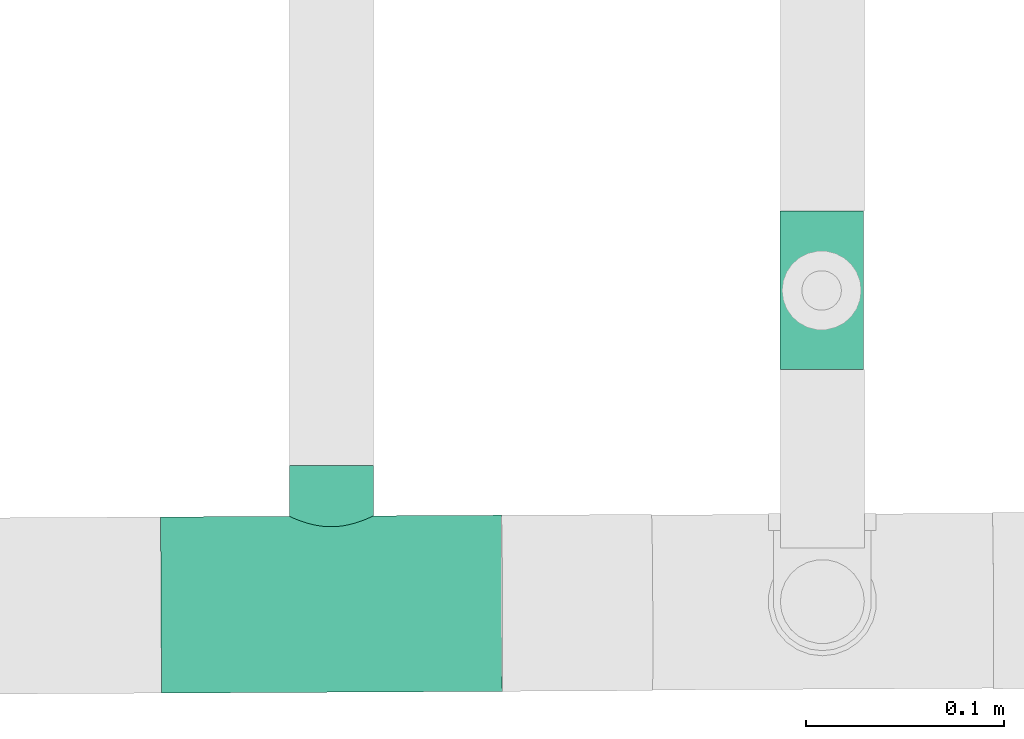
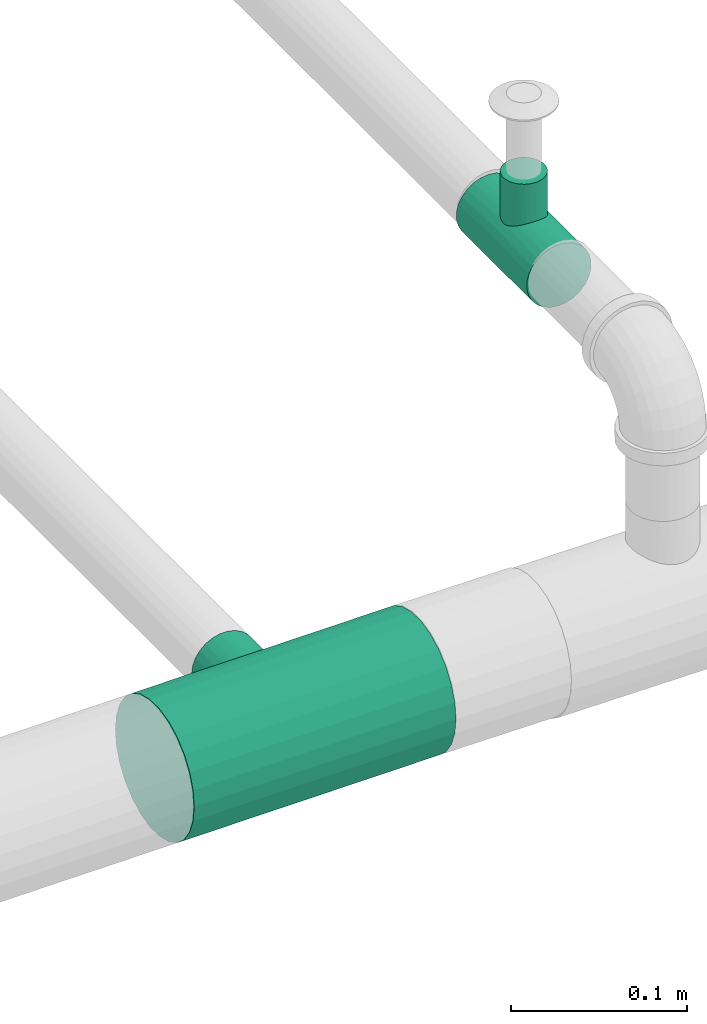
# One storey, part 4 of 7: 2 pipe fittings.
"""IFC4 building model written with IfcOpenShell, lengths in millimetres."""

from ifc_helpers import new_model, entity, si_unit, converted_unit, derived_unit, direction, frame, origin, place, context, subcontext, project, spatial, source, transform, mapped, type_object, type_shapes, element, save


model = new_model("IFC4")

# Units and contexts
model_context = context("Model", 3, precision=0.01, world=origin(), true_north=direction((6.12303176911189e-17, 1.0)))
body_context = subcontext(model_context, "Body", "Model", "MODEL_VIEW")
ifc_project = project(units=[si_unit("LENGTHUNIT", "METRE", prefix="MILLI"), si_unit("AREAUNIT", "SQUARE_METRE"), si_unit("VOLUMEUNIT", "CUBIC_METRE"), converted_unit("PLANEANGLEUNIT", "DEGREE", entity("IfcRatioMeasure", 0.0174532925199433), si_unit("PLANEANGLEUNIT", "RADIAN"), dimensions=[0, 0, 0, 0, 0, 0, 0]), si_unit("MASSUNIT", "GRAM", prefix="KILO"), derived_unit("MASSDENSITYUNIT", [(si_unit("MASSUNIT", "GRAM", prefix="KILO"), 1), (si_unit("LENGTHUNIT", "METRE"), -3)]), derived_unit("MOMENTOFINERTIAUNIT", [(si_unit("LENGTHUNIT", "METRE"), 4)]), si_unit("TIMEUNIT", "SECOND"), si_unit("FREQUENCYUNIT", "HERTZ"), si_unit("THERMODYNAMICTEMPERATUREUNIT", "DEGREE_CELSIUS"), derived_unit("THERMALTRANSMITTANCEUNIT", [(si_unit("MASSUNIT", "GRAM", prefix="KILO"), 1), (si_unit("THERMODYNAMICTEMPERATUREUNIT", "KELVIN"), -1), (si_unit("TIMEUNIT", "SECOND"), -3)]), derived_unit("VOLUMETRICFLOWRATEUNIT", [(si_unit("LENGTHUNIT", "METRE"), 3), (si_unit("TIMEUNIT", "SECOND"), -1)]), si_unit("ELECTRICCURRENTUNIT", "AMPERE"), si_unit("ELECTRICVOLTAGEUNIT", "VOLT"), si_unit("POWERUNIT", "WATT"), si_unit("FORCEUNIT", "NEWTON", prefix="KILO"), si_unit("ILLUMINANCEUNIT", "LUX"), si_unit("LUMINOUSFLUXUNIT", "LUMEN"), si_unit("LUMINOUSINTENSITYUNIT", "CANDELA"), derived_unit("USERDEFINED", [(si_unit("MASSUNIT", "GRAM", prefix="KILO"), -1), (si_unit("LENGTHUNIT", "METRE"), -2), (si_unit("TIMEUNIT", "SECOND"), 3), (si_unit("LUMINOUSFLUXUNIT", "LUMEN"), 1)]), derived_unit("LINEARVELOCITYUNIT", [(si_unit("LENGTHUNIT", "METRE"), 1), (si_unit("TIMEUNIT", "SECOND"), -1)]), si_unit("PRESSUREUNIT", "PASCAL"), derived_unit("USERDEFINED", [(si_unit("LENGTHUNIT", "METRE"), -2), (si_unit("MASSUNIT", "GRAM", prefix="KILO"), 1), (si_unit("TIMEUNIT", "SECOND"), -2)]), derived_unit("LINEARFORCEUNIT", [(si_unit("MASSUNIT", "GRAM", prefix="KILO"), 1), (si_unit("LENGTHUNIT", "METRE"), 1), (si_unit("TIMEUNIT", "SECOND"), -2), (si_unit("LENGTHUNIT", "METRE"), -1)]), derived_unit("PLANARFORCEUNIT", [(si_unit("MASSUNIT", "GRAM", prefix="KILO"), 1), (si_unit("LENGTHUNIT", "METRE"), 1), (si_unit("TIMEUNIT", "SECOND"), -2), (si_unit("LENGTHUNIT", "METRE"), -2)])], contexts=[model_context])

# Site, building, storey
site_placement = place(None, origin())
site = spatial("IfcSite", under=ifc_project, at=site_placement, CompositionType="ELEMENT")
building_placement = place(site_placement, origin())
building = spatial("IfcBuilding", under=site, at=building_placement, CompositionType="ELEMENT")
storey_placement = place(building_placement, origin())
storey = spatial("IfcBuildingStorey", under=building, at=storey_placement, Name="Ebene 1", CompositionType="ELEMENT", Elevation=0.0)

# Pipe fittings
pipe_fitting_type_1 = type_object("IfcPipeFittingType", PredefinedType="NOTDEFINED")
cartesian_point_1 = entity("IfcCartesianPoint", [-40.0, -21.2, 0.0])
vertex_point_1 = entity("IfcVertexPoint", cartesian_point_1)
cartesian_point_2 = entity("IfcCartesianPoint", [-40.0, 21.2, 0.0])
vertex_point_2 = entity("IfcVertexPoint", cartesian_point_2)
cartesian_point_3 = entity("IfcCartesianPoint", [-40.0, 0.0, 0.0])
ifc_direction_1 = entity("IfcDirection", [-1.0, 0.0, 0.0])
ifc_direction_2 = entity("IfcDirection", [0.0, 1.0, 0.0])
edge_curve_1 = entity("IfcEdgeCurve", vertex_point_1, vertex_point_2, entity("IfcTrimmedCurve", entity("IfcCircle", entity("IfcAxis2Placement3D", cartesian_point_3, ifc_direction_1, ifc_direction_2), 21.2), [cartesian_point_1], [cartesian_point_2], True, "CARTESIAN"), True)
edge_curve_2 = entity("IfcEdgeCurve", vertex_point_2, vertex_point_1, entity("IfcTrimmedCurve", entity("IfcCircle", entity("IfcAxis2Placement3D", cartesian_point_3, ifc_direction_1, ifc_direction_2), 21.2), [cartesian_point_2], [cartesian_point_1], True, "CARTESIAN"), True)
ifc_direction_3 = entity("IfcDirection", [0.0, 0.0, 1.0])
cartesian_point_4 = entity("IfcCartesianPoint", [-13.4499999999997, -21.2, 0.0])
vertex_point_3 = entity("IfcVertexPoint", cartesian_point_4)
ifc_direction_4 = entity("IfcDirection", [1.0, 0.0, 0.0])
edge_curve_3 = entity("IfcEdgeCurve", vertex_point_1, vertex_point_3, entity("IfcTrimmedCurve", entity("IfcLine", cartesian_point_1, entity("IfcVector", ifc_direction_4, 304.8)), [cartesian_point_1], [cartesian_point_4], True, "CARTESIAN"), True)
cartesian_point_5 = entity("IfcCartesianPoint", [0.0, -16.3871138398439, 13.4499999999999])
vertex_point_4 = entity("IfcVertexPoint", cartesian_point_5)
edge_curve_4 = entity("IfcEdgeCurve", vertex_point_3, vertex_point_4, entity("IfcBSplineCurveWithKnots", 3, [cartesian_point_4, entity("IfcCartesianPoint", [-13.4426718173683, -21.2, 1.05530479408136]), entity("IfcCartesianPoint", [-13.2097756163524, -21.0441868349683, 3.10767628539556]), entity("IfcCartesianPoint", [-12.1609162088206, -20.397991088886, 6.00505446288426]), entity("IfcCartesianPoint", [-10.5469284915267, -19.4669340412135, 8.51865656427646]), entity("IfcCartesianPoint", [-8.63574644559518, -18.49532904545, 10.4164641581798]), entity("IfcCartesianPoint", [-7.05510952350422, -17.825657912175, 11.4858433011898]), entity("IfcCartesianPoint", [-6.07427551785178, -17.4735158488194, 12.0060897801005]), entity("IfcCartesianPoint", [-5.40578101167897, -17.2531617437123, 12.3219689547776]), entity("IfcCartesianPoint", [-4.53058927081207, -16.9921793940957, 12.6801028111429]), entity("IfcCartesianPoint", [-3.44008605195583, -16.729896481067, 13.0228623624602]), entity("IfcCartesianPoint", [-1.95789476503921, -16.4810375094563, 13.336536578552]), entity("IfcCartesianPoint", [-0.795851700402365, -16.3955749834363, 13.4396911729914]), cartesian_point_5], "UNSPECIFIED", False, "UNKNOWN", [4, 1, 1, 1, 1, 1, 1, 1, 1, 1, 1, 4], [0.0, 0.142857142857143, 0.285714285714286, 0.428571428571429, 0.571428571428571, 0.678571428571429, 0.705357142857143, 0.732142857142857, 0.785714285714286, 0.839285714285714, 0.892857142857143, 1.0], "UNSPECIFIED"), True)
cartesian_point_6 = entity("IfcCartesianPoint", [0.0, 21.2, 0.0])
vertex_point_5 = entity("IfcVertexPoint", cartesian_point_6)
cartesian_point_7 = entity("IfcCartesianPoint", [0.0, 0.0, 0.0])
edge_curve_5 = entity("IfcEdgeCurve", vertex_point_4, vertex_point_5, entity("IfcTrimmedCurve", entity("IfcCircle", entity("IfcAxis2Placement3D", cartesian_point_7, ifc_direction_1, ifc_direction_2), 21.2), [cartesian_point_5], [cartesian_point_6], True, "CARTESIAN"), True)
edge_curve_6 = entity("IfcEdgeCurve", vertex_point_5, vertex_point_2, entity("IfcTrimmedCurve", entity("IfcLine", cartesian_point_2, entity("IfcVector", ifc_direction_1, 304.8)), [cartesian_point_6], [cartesian_point_2], True, "CARTESIAN"), True)
cartesian_point_8 = entity("IfcCartesianPoint", [0.0, -16.3871138398438, -13.45])
vertex_point_6 = entity("IfcVertexPoint", cartesian_point_8)
edge_curve_7 = entity("IfcEdgeCurve", vertex_point_5, vertex_point_6, entity("IfcTrimmedCurve", entity("IfcCircle", entity("IfcAxis2Placement3D", cartesian_point_7, ifc_direction_1, ifc_direction_2), 21.2), [cartesian_point_6], [cartesian_point_8], True, "CARTESIAN"), True)
edge_curve_8 = entity("IfcEdgeCurve", vertex_point_6, vertex_point_3, entity("IfcBSplineCurveWithKnots", 3, [cartesian_point_8, entity("IfcCartesianPoint", [-0.530567800268229, -16.3927546022388, -13.443127448661]), entity("IfcCartesianPoint", [-1.57322183506307, -16.4472972724825, -13.3768527398099]), entity("IfcCartesianPoint", [-3.07552569521692, -16.6498835557472, -13.1256228919224]), entity("IfcCartesianPoint", [-4.29162915568002, -16.9288024160368, -12.7647972300529]), entity("IfcCartesianPoint", [-5.23159362826072, -17.200165075527, -12.3950483027885]), entity("IfcCartesianPoint", [-6.13646755642774, -17.4882712267364, -11.9882121037541]), entity("IfcCartesianPoint", [-7.21336443959599, -17.8915799642873, -11.3853223452529]), entity("IfcCartesianPoint", [-8.8092327863119, -18.5829320362105, -10.244778111581]), entity("IfcCartesianPoint", [-10.3708595681595, -19.3781525936877, -8.69330270117763]), entity("IfcCartesianPoint", [-11.5633465632856, -20.0508934534462, -6.94488315746441]), entity("IfcCartesianPoint", [-12.2393860181753, -20.4531409633993, -5.6114001730771]), entity("IfcCartesianPoint", [-12.6719579269079, -20.7152170553906, -4.55307873733241]), entity("IfcCartesianPoint", [-13.0180907128958, -20.927114158807, -3.45234159916712]), entity("IfcCartesianPoint", [-13.3415546521607, -21.1333274469641, -1.95734501707586]), entity("IfcCartesianPoint", [-13.4445038630262, -21.2, -0.791478595561123]), cartesian_point_4], "UNSPECIFIED", False, "UNKNOWN", [4, 1, 1, 1, 1, 1, 1, 1, 1, 1, 1, 1, 1, 1, 4], [0.0, 0.0714285714285714, 0.142857142857143, 0.214285714285714, 0.25, 0.285714285714286, 0.357142857142857, 0.428571428571429, 0.571428571428571, 0.678571428571429, 0.732142857142857, 0.785714285714286, 0.839285714285714, 0.892857142857143, 1.0], "UNSPECIFIED"), True)
cartesian_point_9 = entity("IfcCartesianPoint", [40.0, -21.2, 0.0])
vertex_point_7 = entity("IfcVertexPoint", cartesian_point_9)
cartesian_point_10 = entity("IfcCartesianPoint", [40.0, 21.2, 0.0])
vertex_point_8 = entity("IfcVertexPoint", cartesian_point_10)
cartesian_point_11 = entity("IfcCartesianPoint", [40.0, 0.0, 0.0])
edge_curve_9 = entity("IfcEdgeCurve", vertex_point_7, vertex_point_8, entity("IfcTrimmedCurve", entity("IfcCircle", entity("IfcAxis2Placement3D", cartesian_point_11, ifc_direction_4, ifc_direction_2), 21.2), [cartesian_point_9], [cartesian_point_10], True, "CARTESIAN"), True)
edge_curve_10 = entity("IfcEdgeCurve", vertex_point_8, vertex_point_7, entity("IfcTrimmedCurve", entity("IfcCircle", entity("IfcAxis2Placement3D", cartesian_point_11, ifc_direction_4, ifc_direction_2), 21.2), [cartesian_point_10], [cartesian_point_9], True, "CARTESIAN"), True)
edge_curve_11 = entity("IfcEdgeCurve", vertex_point_8, vertex_point_5, entity("IfcTrimmedCurve", entity("IfcLine", cartesian_point_6, entity("IfcVector", ifc_direction_1, 304.8)), [cartesian_point_10], [cartesian_point_6], True, "CARTESIAN"), True)
cartesian_point_12 = entity("IfcCartesianPoint", [13.4500000000003, -21.2, 0.0])
vertex_point_9 = entity("IfcVertexPoint", cartesian_point_12)
edge_curve_12 = entity("IfcEdgeCurve", vertex_point_4, vertex_point_9, entity("IfcBSplineCurveWithKnots", 3, [cartesian_point_5, entity("IfcCartesianPoint", [0.531634819858689, -16.3928819135239, 13.442972336057]), entity("IfcCartesianPoint", [1.57607123818477, -16.4476933205109, 13.3763690869294]), entity("IfcCartesianPoint", [3.08013692881612, -16.6506796779383, 13.1246211485699]), entity("IfcCartesianPoint", [4.29659073867082, -16.9299917267641, 12.7632282221071]), entity("IfcCartesianPoint", [5.23642769214472, -17.2016325394637, 12.393015409334]), entity("IfcCartesianPoint", [6.14120270583486, -17.4899444504475, 11.9857781136098]), entity("IfcCartesianPoint", [7.21777415311232, -17.8933341358018, 11.3825736824291]), entity("IfcCartesianPoint", [8.81288762772699, -18.5847111247634, 10.2415736340777]), entity("IfcCartesianPoint", [10.3740935708438, -19.3798792732465, 8.68951359025296]), entity("IfcCartesianPoint", [11.5659357420418, -20.0524195056715, 6.94048257577652]), entity("IfcCartesianPoint", [12.2414593668596, -20.4543687508565, 5.60692331292446]), entity("IfcCartesianPoint", [12.673530290567, -20.7162241328193, 4.54849434738574]), entity("IfcCartesianPoint", [13.0191628472021, -20.9278248733526, 3.44796327191625]), entity("IfcCartesianPoint", [13.3420958063374, -21.1335673799666, 1.95422154961542]), entity("IfcCartesianPoint", [13.4447017410778, -21.2, 0.790026683599578]), cartesian_point_12], "UNSPECIFIED", False, "UNKNOWN", [4, 1, 1, 1, 1, 1, 1, 1, 1, 1, 1, 1, 1, 1, 4], [0.0, 0.0714285714285714, 0.142857142857143, 0.214285714285714, 0.25, 0.285714285714286, 0.357142857142857, 0.428571428571429, 0.571428571428571, 0.678571428571429, 0.732142857142857, 0.785714285714286, 0.839285714285714, 0.892857142857143, 1.0], "UNSPECIFIED"), True)
edge_curve_13 = entity("IfcEdgeCurve", vertex_point_9, vertex_point_7, entity("IfcTrimmedCurve", entity("IfcLine", cartesian_point_12, entity("IfcVector", ifc_direction_4, 304.8)), [cartesian_point_12], [cartesian_point_9], True, "CARTESIAN"), True)
edge_curve_14 = entity("IfcEdgeCurve", vertex_point_9, vertex_point_6, entity("IfcBSplineCurveWithKnots", 3, [cartesian_point_12, entity("IfcCartesianPoint", [13.4429356547703, -21.2, -1.05336891146624]), entity("IfcCartesianPoint", [13.2106284272924, -21.0448079646393, -3.10290146454885]), entity("IfcCartesianPoint", [12.1632059848055, -20.3993567445884, -6.00052882100487]), entity("IfcCartesianPoint", [10.5500999116973, -19.4686677379271, -8.51474527268791]), entity("IfcCartesianPoint", [8.63944721325947, -18.497105971094, -10.4133430093872]), entity("IfcCartesianPoint", [7.05961182247531, -17.8274179790001, -11.4831210854999]), entity("IfcCartesianPoint", [6.07901331931581, -17.4751595806235, -12.0036988371641]), entity("IfcCartesianPoint", [5.41057777067569, -17.2546782201018, -12.3198496975246]), entity("IfcCartesianPoint", [4.53554903963236, -16.9934445856902, -12.6784155954797]), entity("IfcCartesianPoint", [3.44485713961686, -16.7308038767085, -13.021701977829]), entity("IfcCartesianPoint", [1.96131523211392, -16.4815361622911, -13.3359276598797]), entity("IfcCartesianPoint", [0.797452229788015, -16.3957659503639, -13.4394585040857]), cartesian_point_8], "UNSPECIFIED", False, "UNKNOWN", [4, 1, 1, 1, 1, 1, 1, 1, 1, 1, 1, 4], [0.0, 0.142857142857143, 0.285714285714286, 0.428571428571429, 0.571428571428571, 0.678571428571429, 0.705357142857143, 0.732142857142857, 0.785714285714286, 0.839285714285714, 0.892857142857143, 1.0], "UNSPECIFIED"), True)
cartesian_point_13 = entity("IfcCartesianPoint", [-13.4499999999997, -48.0, 0.0])
vertex_point_10 = entity("IfcVertexPoint", cartesian_point_13)
cartesian_point_14 = entity("IfcCartesianPoint", [13.4500000000003, -48.0, 0.0])
vertex_point_11 = entity("IfcVertexPoint", cartesian_point_14)
cartesian_point_15 = entity("IfcCartesianPoint", [0.0, -48.0, 0.0])
ifc_direction_5 = entity("IfcDirection", [0.0, -1.0, 0.0])
edge_curve_15 = entity("IfcEdgeCurve", vertex_point_10, vertex_point_11, entity("IfcTrimmedCurve", entity("IfcCircle", entity("IfcAxis2Placement3D", cartesian_point_15, ifc_direction_5, ifc_direction_4), 13.45), [cartesian_point_13], [cartesian_point_14], True, "CARTESIAN"), True)
edge_curve_16 = entity("IfcEdgeCurve", vertex_point_11, vertex_point_10, entity("IfcTrimmedCurve", entity("IfcCircle", entity("IfcAxis2Placement3D", cartesian_point_15, ifc_direction_5, ifc_direction_4), 13.45), [cartesian_point_14], [cartesian_point_13], True, "CARTESIAN"), True)
edge_curve_17 = entity("IfcEdgeCurve", vertex_point_11, vertex_point_9, entity("IfcTrimmedCurve", entity("IfcLine", cartesian_point_12, entity("IfcVector", ifc_direction_2, 304.8)), [cartesian_point_14], [cartesian_point_12], True, "CARTESIAN"), True)
edge_curve_18 = entity("IfcEdgeCurve", vertex_point_3, vertex_point_10, entity("IfcTrimmedCurve", entity("IfcLine", cartesian_point_4, entity("IfcVector", ifc_direction_5, 304.8)), [cartesian_point_4], [cartesian_point_13], True, "CARTESIAN"), True)
shared_shape_1 = source(origin(), body_context, "Body", "AdvancedBrep", [
    entity("IfcAdvancedBrep", entity("IfcClosedShell", [entity("IfcAdvancedFace", [entity("IfcFaceOuterBound", entity("IfcEdgeLoop", [entity("IfcOrientedEdge", None, None, edge_curve_1, True), entity("IfcOrientedEdge", None, None, edge_curve_2, True)]), True)], entity("IfcPlane", entity("IfcAxis2Placement3D", cartesian_point_3, ifc_direction_1, ifc_direction_3)), True), entity("IfcAdvancedFace", [entity("IfcFaceOuterBound", entity("IfcEdgeLoop", [entity("IfcOrientedEdge", None, None, edge_curve_1, False), entity("IfcOrientedEdge", None, None, edge_curve_3, True), entity("IfcOrientedEdge", None, None, edge_curve_4, True), entity("IfcOrientedEdge", None, None, edge_curve_5, True), entity("IfcOrientedEdge", None, None, edge_curve_6, True)]), True)], entity("IfcCylindricalSurface", entity("IfcAxis2Placement3D", cartesian_point_3, ifc_direction_1, ifc_direction_2), 21.2), True), entity("IfcAdvancedFace", [entity("IfcFaceOuterBound", entity("IfcEdgeLoop", [entity("IfcOrientedEdge", None, None, edge_curve_2, False), entity("IfcOrientedEdge", None, None, edge_curve_6, False), entity("IfcOrientedEdge", None, None, edge_curve_7, True), entity("IfcOrientedEdge", None, None, edge_curve_8, True), entity("IfcOrientedEdge", None, None, edge_curve_3, False)]), True)], entity("IfcCylindricalSurface", entity("IfcAxis2Placement3D", cartesian_point_3, ifc_direction_1, ifc_direction_2), 21.2), True), entity("IfcAdvancedFace", [entity("IfcFaceOuterBound", entity("IfcEdgeLoop", [entity("IfcOrientedEdge", None, None, edge_curve_9, True), entity("IfcOrientedEdge", None, None, edge_curve_10, True)]), True)], entity("IfcPlane", entity("IfcAxis2Placement3D", cartesian_point_11, ifc_direction_4, ifc_direction_3)), True), entity("IfcAdvancedFace", [entity("IfcFaceOuterBound", entity("IfcEdgeLoop", [entity("IfcOrientedEdge", None, None, edge_curve_10, False), entity("IfcOrientedEdge", None, None, edge_curve_11, True), entity("IfcOrientedEdge", None, None, edge_curve_5, False), entity("IfcOrientedEdge", None, None, edge_curve_12, True), entity("IfcOrientedEdge", None, None, edge_curve_13, True)]), True)], entity("IfcCylindricalSurface", entity("IfcAxis2Placement3D", cartesian_point_7, ifc_direction_1, ifc_direction_2), 21.2), True), entity("IfcAdvancedFace", [entity("IfcFaceOuterBound", entity("IfcEdgeLoop", [entity("IfcOrientedEdge", None, None, edge_curve_9, False), entity("IfcOrientedEdge", None, None, edge_curve_13, False), entity("IfcOrientedEdge", None, None, edge_curve_14, True), entity("IfcOrientedEdge", None, None, edge_curve_7, False), entity("IfcOrientedEdge", None, None, edge_curve_11, False)]), True)], entity("IfcCylindricalSurface", entity("IfcAxis2Placement3D", cartesian_point_7, ifc_direction_1, ifc_direction_2), 21.2), True), entity("IfcAdvancedFace", [entity("IfcFaceOuterBound", entity("IfcEdgeLoop", [entity("IfcOrientedEdge", None, None, edge_curve_15, True), entity("IfcOrientedEdge", None, None, edge_curve_16, True)]), True)], entity("IfcPlane", entity("IfcAxis2Placement3D", cartesian_point_15, ifc_direction_5, ifc_direction_3)), True), entity("IfcAdvancedFace", [entity("IfcFaceOuterBound", entity("IfcEdgeLoop", [entity("IfcOrientedEdge", None, None, edge_curve_16, False), entity("IfcOrientedEdge", None, None, edge_curve_17, True), entity("IfcOrientedEdge", None, None, edge_curve_12, False), entity("IfcOrientedEdge", None, None, edge_curve_4, False), entity("IfcOrientedEdge", None, None, edge_curve_18, True)]), True)], entity("IfcCylindricalSurface", entity("IfcAxis2Placement3D", cartesian_point_7, ifc_direction_2, ifc_direction_4), 13.45), True), entity("IfcAdvancedFace", [entity("IfcFaceOuterBound", entity("IfcEdgeLoop", [entity("IfcOrientedEdge", None, None, edge_curve_15, False), entity("IfcOrientedEdge", None, None, edge_curve_18, False), entity("IfcOrientedEdge", None, None, edge_curve_8, False), entity("IfcOrientedEdge", None, None, edge_curve_14, False), entity("IfcOrientedEdge", None, None, edge_curve_17, False)]), True)], entity("IfcCylindricalSurface", entity("IfcAxis2Placement3D", cartesian_point_7, ifc_direction_2, ifc_direction_4), 13.45), True)])),
])
type_shapes(pipe_fitting_type_1, [shared_shape_1])
pipe_fitting_1_placement = place(storey_placement, frame((10775.1960454703, 95065.7642157737, 3786.41335126022), z_axis=(1.0, 0.0, 0.0), x_axis=(0.0, -1.0, 0.0)))
element("IfcPipeFitting", 1, at=pipe_fitting_1_placement, inside=storey, type_object=pipe_fitting_type_1, PredefinedType="NOTDEFINED", context=body_context, shape_type="MappedRepresentation", body=[
    mapped(shared_shape_1, transform((0.0, 0.0, 0.0), scale=1.0)),
])
pipe_fitting_type_2 = type_object("IfcPipeFittingType", PredefinedType="NOTDEFINED")
cartesian_point_16 = entity("IfcCartesianPoint", [-86.0, -44.45, 0.0])
vertex_point_12 = entity("IfcVertexPoint", cartesian_point_16)
cartesian_point_17 = entity("IfcCartesianPoint", [-86.0, 44.45, 0.0])
vertex_point_13 = entity("IfcVertexPoint", cartesian_point_17)
cartesian_point_18 = entity("IfcCartesianPoint", [-86.0, 0.0, 0.0])
ifc_direction_6 = entity("IfcDirection", [-1.0, 0.0, 0.0])
ifc_direction_7 = entity("IfcDirection", [0.0, 1.0, 0.0])
edge_curve_19 = entity("IfcEdgeCurve", vertex_point_12, vertex_point_13, entity("IfcTrimmedCurve", entity("IfcCircle", entity("IfcAxis2Placement3D", cartesian_point_18, ifc_direction_6, ifc_direction_7), 44.45), [cartesian_point_16], [cartesian_point_17], True, "CARTESIAN"), True)
edge_curve_20 = entity("IfcEdgeCurve", vertex_point_13, vertex_point_12, entity("IfcTrimmedCurve", entity("IfcCircle", entity("IfcAxis2Placement3D", cartesian_point_18, ifc_direction_6, ifc_direction_7), 44.45), [cartesian_point_17], [cartesian_point_16], True, "CARTESIAN"), True)
ifc_direction_8 = entity("IfcDirection", [0.0, 0.0, 1.0])
cartesian_point_19 = entity("IfcCartesianPoint", [-20.9701622426132, -44.45, 0.0])
vertex_point_14 = entity("IfcVertexPoint", cartesian_point_19)
ifc_direction_9 = entity("IfcDirection", [1.0, 0.0, 0.0])
edge_curve_21 = entity("IfcEdgeCurve", vertex_point_12, vertex_point_14, entity("IfcTrimmedCurve", entity("IfcLine", cartesian_point_16, entity("IfcVector", ifc_direction_9, 304.8)), [cartesian_point_16], [cartesian_point_19], True, "CARTESIAN"), True)
cartesian_point_20 = entity("IfcCartesianPoint", [0.0, -39.0692130716808, 21.1990351185994])
vertex_point_15 = entity("IfcVertexPoint", cartesian_point_20)
edge_curve_22 = entity("IfcEdgeCurve", vertex_point_14, vertex_point_15, entity("IfcBSplineCurveWithKnots", 3, [cartesian_point_19, entity("IfcCartesianPoint", [-20.9621839055707, -44.45, 1.62759004262834]), entity("IfcCartesianPoint", [-20.6087947284972, -44.2734964026675, 4.79318958429066]), entity("IfcCartesianPoint", [-18.480794112754, -43.2912756222942, 10.8257496463721]), entity("IfcCartesianPoint", [-14.7888076583015, -41.751565040865, 15.4596935582272]), entity("IfcCartesianPoint", [-10.746274474178, -40.5528562359455, 18.2190020170452]), entity("IfcCartesianPoint", [-8.66832869672662, -40.0551535549336, 19.277132056593]), entity("IfcCartesianPoint", [-7.02295217752, -39.7215840284126, 19.9538190583781]), entity("IfcCartesianPoint", [-5.31885410548397, -39.4434806994973, 20.4964536603658]), entity("IfcCartesianPoint", [-3.01691593326901, -39.1744942623043, 21.0062373586355]), entity("IfcCartesianPoint", [-1.22330180749222, -39.0804841917142, 21.1782627679862]), cartesian_point_20], "UNSPECIFIED", False, "UNKNOWN", [4, 1, 1, 1, 1, 1, 1, 1, 1, 4], [0.0, 0.142857142857143, 0.285714285714286, 0.571428571428571, 0.678571428571429, 0.732142857142857, 0.785714285714286, 0.839285714285714, 0.892857142857143, 1.0], "UNSPECIFIED"), True)
cartesian_point_21 = entity("IfcCartesianPoint", [0.0, 44.45, 0.0])
vertex_point_16 = entity("IfcVertexPoint", cartesian_point_21)
cartesian_point_22 = entity("IfcCartesianPoint", [0.0, 0.0, 0.0])
edge_curve_23 = entity("IfcEdgeCurve", vertex_point_15, vertex_point_16, entity("IfcTrimmedCurve", entity("IfcCircle", entity("IfcAxis2Placement3D", cartesian_point_22, ifc_direction_6, ifc_direction_7), 44.45), [cartesian_point_20], [cartesian_point_21], True, "CARTESIAN"), True)
edge_curve_24 = entity("IfcEdgeCurve", vertex_point_16, vertex_point_13, entity("IfcTrimmedCurve", entity("IfcLine", cartesian_point_17, entity("IfcVector", ifc_direction_6, 304.8)), [cartesian_point_21], [cartesian_point_17], True, "CARTESIAN"), True)
cartesian_point_23 = entity("IfcCartesianPoint", [0.0, -39.0692130716806, -21.1990351185996])
vertex_point_17 = entity("IfcVertexPoint", cartesian_point_23)
edge_curve_25 = entity("IfcEdgeCurve", vertex_point_16, vertex_point_17, entity("IfcTrimmedCurve", entity("IfcCircle", entity("IfcAxis2Placement3D", cartesian_point_22, ifc_direction_6, ifc_direction_7), 44.45), [cartesian_point_21], [cartesian_point_23], True, "CARTESIAN"), True)
edge_curve_26 = entity("IfcEdgeCurve", vertex_point_17, vertex_point_14, entity("IfcBSplineCurveWithKnots", 3, [cartesian_point_23, entity("IfcCartesianPoint", [-1.63106907665627, -39.0842412317253, -21.1713386511152]), entity("IfcCartesianPoint", [-4.78074938054347, -39.2926642438718, -20.7931459670072]), entity("IfcCartesianPoint", [-9.2736998816664, -40.1324113616692, -19.1568658094622]), entity("IfcCartesianPoint", [-13.2176696473769, -41.2654605404322, -16.6213876430327]), entity("IfcCartesianPoint", [-17.0552932192725, -42.6723610132628, -12.7524758007646]), entity("IfcCartesianPoint", [-20.1435241708323, -44.044687403368, -7.18251464579851]), entity("IfcCartesianPoint", [-20.9581947370495, -44.45, -2.44138506394285]), cartesian_point_19], "UNSPECIFIED", False, "UNKNOWN", [4, 1, 1, 1, 1, 1, 4], [0.0, 0.142857142857143, 0.285714285714286, 0.428571428571429, 0.571428571428571, 0.785714285714286, 1.0], "UNSPECIFIED"), True)
cartesian_point_24 = entity("IfcCartesianPoint", [86.0, -44.45, 0.0])
vertex_point_18 = entity("IfcVertexPoint", cartesian_point_24)
cartesian_point_25 = entity("IfcCartesianPoint", [86.0, 44.45, 0.0])
vertex_point_19 = entity("IfcVertexPoint", cartesian_point_25)
cartesian_point_26 = entity("IfcCartesianPoint", [86.0, 0.0, 0.0])
edge_curve_27 = entity("IfcEdgeCurve", vertex_point_18, vertex_point_19, entity("IfcTrimmedCurve", entity("IfcCircle", entity("IfcAxis2Placement3D", cartesian_point_26, ifc_direction_9, ifc_direction_7), 44.45), [cartesian_point_24], [cartesian_point_25], True, "CARTESIAN"), True)
edge_curve_28 = entity("IfcEdgeCurve", vertex_point_19, vertex_point_18, entity("IfcTrimmedCurve", entity("IfcCircle", entity("IfcAxis2Placement3D", cartesian_point_26, ifc_direction_9, ifc_direction_7), 44.45), [cartesian_point_25], [cartesian_point_24], True, "CARTESIAN"), True)
edge_curve_29 = entity("IfcEdgeCurve", vertex_point_19, vertex_point_16, entity("IfcTrimmedCurve", entity("IfcLine", cartesian_point_21, entity("IfcVector", ifc_direction_6, 304.8)), [cartesian_point_25], [cartesian_point_21], True, "CARTESIAN"), True)
cartesian_point_27 = entity("IfcCartesianPoint", [21.4304059625443, -44.45, 0.0])
vertex_point_20 = entity("IfcVertexPoint", cartesian_point_27)
edge_curve_30 = entity("IfcEdgeCurve", vertex_point_15, vertex_point_20, entity("IfcBSplineCurveWithKnots", 3, [cartesian_point_20, entity("IfcCartesianPoint", [1.65604453289422, -39.0675647052296, 21.2020730106422]), entity("IfcCartesianPoint", [4.8580916878117, -39.2487653405849, 20.8744895359032]), entity("IfcCartesianPoint", [9.44204138378133, -40.0718893346729, 19.2818985471389]), entity("IfcCartesianPoint", [13.4738559547255, -41.2081558165382, 16.7628328388283]), entity("IfcCartesianPoint", [17.4055386502552, -42.633329529404, 12.885980582725]), entity("IfcCartesianPoint", [20.5797491094026, -44.0349038061849, 7.26661811512843]), entity("IfcCartesianPoint", [21.4181295078993, -44.45, 2.46984238164798]), cartesian_point_27], "UNSPECIFIED", False, "UNKNOWN", [4, 1, 1, 1, 1, 1, 4], [0.0, 0.142857142857143, 0.285714285714286, 0.428571428571429, 0.571428571428571, 0.785714285714286, 1.0], "UNSPECIFIED"), True)
edge_curve_31 = entity("IfcEdgeCurve", vertex_point_20, vertex_point_18, entity("IfcTrimmedCurve", entity("IfcLine", cartesian_point_27, entity("IfcVector", ifc_direction_9, 304.8)), [cartesian_point_27], [cartesian_point_24], True, "CARTESIAN"), True)
edge_curve_32 = entity("IfcEdgeCurve", vertex_point_20, vertex_point_17, entity("IfcBSplineCurveWithKnots", 3, [cartesian_point_27, entity("IfcCartesianPoint", [21.4222216594476, -44.45, -1.64656158776552]), entity("IfcCartesianPoint", [21.0591038139161, -44.2694994660559, -4.8477759359088]), entity("IfcCartesianPoint", [18.8695035893847, -43.2644124137519, -10.947727771941]), entity("IfcCartesianPoint", [15.0810727154372, -41.6972883623653, -15.6048401174867]), entity("IfcCartesianPoint", [10.9471382589172, -40.493317862358, -18.3505975533345]), entity("IfcCartesianPoint", [8.82524202145581, -39.9985413103497, -19.3941414634767]), entity("IfcCartesianPoint", [7.14600365392203, -39.6698175685772, -20.0563385835102]), entity("IfcCartesianPoint", [5.40852745764945, -39.3996085698657, -20.5804709768802]), entity("IfcCartesianPoint", [3.06506309404727, -39.1458674608779, -21.0591519951062]), entity("IfcCartesianPoint", [1.24203339967065, -39.0679767968423, -21.2013135376316]), cartesian_point_23], "UNSPECIFIED", False, "UNKNOWN", [4, 1, 1, 1, 1, 1, 1, 1, 1, 4], [0.0, 0.142857142857143, 0.285714285714286, 0.571428571428571, 0.678571428571429, 0.732142857142857, 0.785714285714286, 0.839285714285714, 0.892857142857143, 1.0], "UNSPECIFIED"), True)
cartesian_point_28 = entity("IfcCartesianPoint", [-20.8373192713616, -70.1097529370962, 0.0])
vertex_point_21 = entity("IfcVertexPoint", cartesian_point_28)
cartesian_point_29 = entity("IfcCartesianPoint", [21.5621125310954, -69.8902470629038, 0.0])
vertex_point_22 = entity("IfcVertexPoint", cartesian_point_29)
cartesian_point_30 = entity("IfcCartesianPoint", [0.362396629866896, -70.0, 0.0])
edge_curve_33 = entity("IfcEdgeCurve", vertex_point_21, vertex_point_22, entity("IfcTrimmedCurve", entity("IfcCircle", entity("IfcAxis2Placement3D", cartesian_point_30, entity("IfcDirection", [0.00517702533472752, -0.99998659911455, 0.0]), entity("IfcDirection", [0.99998659911455, 0.00517702533472752, 0.0])), 21.2), [cartesian_point_28], [cartesian_point_29], True, "CARTESIAN"), True)
edge_curve_34 = entity("IfcEdgeCurve", vertex_point_22, vertex_point_21, entity("IfcTrimmedCurve", entity("IfcCircle", entity("IfcAxis2Placement3D", cartesian_point_30, entity("IfcDirection", [0.00517702533472752, -0.99998659911455, 0.0]), entity("IfcDirection", [0.99998659911455, 0.00517702533472752, 0.0])), 21.2), [cartesian_point_29], [cartesian_point_28], True, "CARTESIAN"), True)
edge_curve_35 = entity("IfcEdgeCurve", vertex_point_22, vertex_point_20, entity("IfcTrimmedCurve", entity("IfcLine", cartesian_point_27, entity("IfcVector", entity("IfcDirection", [-0.00517702533472759, 0.99998659911455, 0.0]), 304.8)), [cartesian_point_29], [cartesian_point_27], True, "CARTESIAN"), True)
edge_curve_36 = entity("IfcEdgeCurve", vertex_point_14, vertex_point_21, entity("IfcTrimmedCurve", entity("IfcLine", cartesian_point_19, entity("IfcVector", entity("IfcDirection", [0.00517702533472747, -0.99998659911455, 0.0]), 304.8)), [cartesian_point_19], [cartesian_point_28], True, "CARTESIAN"), True)
shared_shape_2 = source(origin(), body_context, "Body", "AdvancedBrep", [
    entity("IfcAdvancedBrep", entity("IfcClosedShell", [entity("IfcAdvancedFace", [entity("IfcFaceOuterBound", entity("IfcEdgeLoop", [entity("IfcOrientedEdge", None, None, edge_curve_19, True), entity("IfcOrientedEdge", None, None, edge_curve_20, True)]), True)], entity("IfcPlane", entity("IfcAxis2Placement3D", cartesian_point_18, ifc_direction_6, ifc_direction_8)), True), entity("IfcAdvancedFace", [entity("IfcFaceOuterBound", entity("IfcEdgeLoop", [entity("IfcOrientedEdge", None, None, edge_curve_19, False), entity("IfcOrientedEdge", None, None, edge_curve_21, True), entity("IfcOrientedEdge", None, None, edge_curve_22, True), entity("IfcOrientedEdge", None, None, edge_curve_23, True), entity("IfcOrientedEdge", None, None, edge_curve_24, True)]), True)], entity("IfcCylindricalSurface", entity("IfcAxis2Placement3D", cartesian_point_18, ifc_direction_6, ifc_direction_7), 44.45), True), entity("IfcAdvancedFace", [entity("IfcFaceOuterBound", entity("IfcEdgeLoop", [entity("IfcOrientedEdge", None, None, edge_curve_20, False), entity("IfcOrientedEdge", None, None, edge_curve_24, False), entity("IfcOrientedEdge", None, None, edge_curve_25, True), entity("IfcOrientedEdge", None, None, edge_curve_26, True), entity("IfcOrientedEdge", None, None, edge_curve_21, False)]), True)], entity("IfcCylindricalSurface", entity("IfcAxis2Placement3D", cartesian_point_18, ifc_direction_6, ifc_direction_7), 44.45), True), entity("IfcAdvancedFace", [entity("IfcFaceOuterBound", entity("IfcEdgeLoop", [entity("IfcOrientedEdge", None, None, edge_curve_27, True), entity("IfcOrientedEdge", None, None, edge_curve_28, True)]), True)], entity("IfcPlane", entity("IfcAxis2Placement3D", cartesian_point_26, ifc_direction_9, ifc_direction_8)), True), entity("IfcAdvancedFace", [entity("IfcFaceOuterBound", entity("IfcEdgeLoop", [entity("IfcOrientedEdge", None, None, edge_curve_28, False), entity("IfcOrientedEdge", None, None, edge_curve_29, True), entity("IfcOrientedEdge", None, None, edge_curve_23, False), entity("IfcOrientedEdge", None, None, edge_curve_30, True), entity("IfcOrientedEdge", None, None, edge_curve_31, True)]), True)], entity("IfcCylindricalSurface", entity("IfcAxis2Placement3D", cartesian_point_22, ifc_direction_6, ifc_direction_7), 44.45), True), entity("IfcAdvancedFace", [entity("IfcFaceOuterBound", entity("IfcEdgeLoop", [entity("IfcOrientedEdge", None, None, edge_curve_27, False), entity("IfcOrientedEdge", None, None, edge_curve_31, False), entity("IfcOrientedEdge", None, None, edge_curve_32, True), entity("IfcOrientedEdge", None, None, edge_curve_25, False), entity("IfcOrientedEdge", None, None, edge_curve_29, False)]), True)], entity("IfcCylindricalSurface", entity("IfcAxis2Placement3D", cartesian_point_22, ifc_direction_6, ifc_direction_7), 44.45), True), entity("IfcAdvancedFace", [entity("IfcFaceOuterBound", entity("IfcEdgeLoop", [entity("IfcOrientedEdge", None, None, edge_curve_33, True), entity("IfcOrientedEdge", None, None, edge_curve_34, True)]), True)], entity("IfcPlane", entity("IfcAxis2Placement3D", cartesian_point_30, entity("IfcDirection", [0.00517702533472752, -0.99998659911455, 0.0]), ifc_direction_8)), True), entity("IfcAdvancedFace", [entity("IfcFaceOuterBound", entity("IfcEdgeLoop", [entity("IfcOrientedEdge", None, None, edge_curve_34, False), entity("IfcOrientedEdge", None, None, edge_curve_35, True), entity("IfcOrientedEdge", None, None, edge_curve_30, False), entity("IfcOrientedEdge", None, None, edge_curve_22, False), entity("IfcOrientedEdge", None, None, edge_curve_36, True)]), True)], entity("IfcCylindricalSurface", entity("IfcAxis2Placement3D", cartesian_point_22, entity("IfcDirection", [-0.00517702533472752, 0.99998659911455, 0.0]), entity("IfcDirection", [0.99998659911455, 0.00517702533472752, 0.0])), 21.2), True), entity("IfcAdvancedFace", [entity("IfcFaceOuterBound", entity("IfcEdgeLoop", [entity("IfcOrientedEdge", None, None, edge_curve_33, False), entity("IfcOrientedEdge", None, None, edge_curve_36, False), entity("IfcOrientedEdge", None, None, edge_curve_26, False), entity("IfcOrientedEdge", None, None, edge_curve_32, False), entity("IfcOrientedEdge", None, None, edge_curve_35, False)]), True)], entity("IfcCylindricalSurface", entity("IfcAxis2Placement3D", cartesian_point_22, entity("IfcDirection", [-0.00517702533472752, 0.99998659911455, 0.0]), entity("IfcDirection", [0.99998659911455, 0.00517702533472752, 0.0])), 21.2), True)])),
])
type_shapes(pipe_fitting_type_2, [shared_shape_2])
pipe_fitting_2_placement = place(storey_placement, frame((10527.7791757466, 94907.4326971711, 3633.83537970106), z_axis=(0.0, 0.0, -1.0), x_axis=(0.99998659911455, 0.00517702533472778, 0.0)))
element("IfcPipeFitting", 2, at=pipe_fitting_2_placement, inside=storey, type_object=pipe_fitting_type_2, PredefinedType="NOTDEFINED", context=body_context, shape_type="MappedRepresentation", body=[
    mapped(shared_shape_2, transform((0.0, 0.0, 0.0), scale=1.0)),
])

save(model, "model.ifc")
